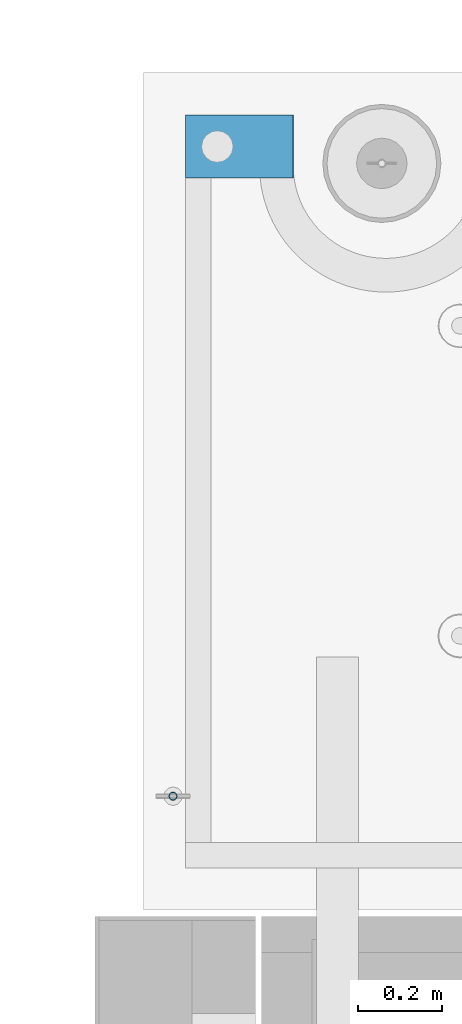
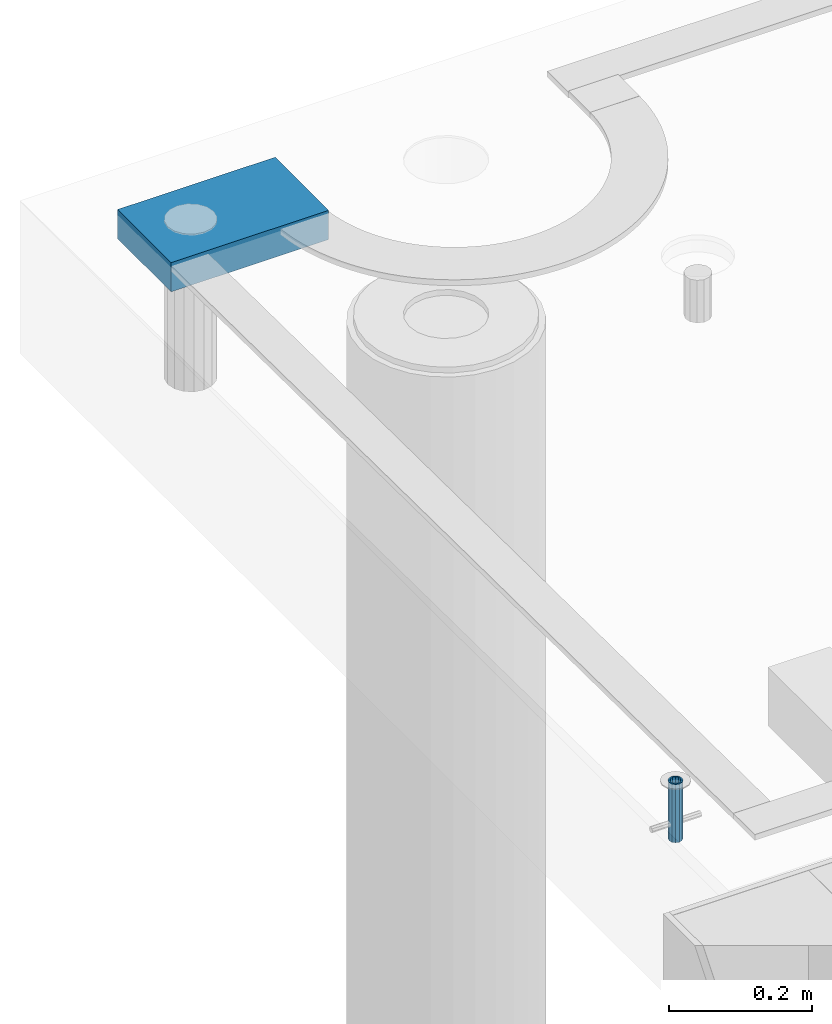
# One storey, part 154 of 350: 2 beams, 2 elements without a shape of their own.
"""IFC2X3 building model written with IfcOpenShell, lengths in millimetres."""

from ifc_helpers import new_model, si_unit, frame, origin_with_axes, place, context, subcontext, project, spatial, faceted_brep, material, type_object, element, aggregate, save


model = new_model("IFC2X3")

# Units and contexts
model_context = context("Model", 3, precision=1e-05, world=origin_with_axes())
body_context = subcontext(model_context, "Body", "Model", "MODEL_VIEW")
ifc_project = project(units=[si_unit("LENGTHUNIT", "METRE", prefix="MILLI"), si_unit("AREAUNIT", "SQUARE_METRE"), si_unit("VOLUMEUNIT", "CUBIC_METRE"), si_unit("MASSUNIT", "GRAM", prefix="KILO"), si_unit("TIMEUNIT", "SECOND"), si_unit("PLANEANGLEUNIT", "RADIAN"), si_unit("SOLIDANGLEUNIT", "STERADIAN"), si_unit("THERMODYNAMICTEMPERATUREUNIT", "DEGREE_CELSIUS"), si_unit("LUMINOUSINTENSITYUNIT", "LUMEN")], contexts=[model_context])

# Site, building, storey
site_placement = place(None, origin_with_axes())
site = spatial("IfcSite", under=ifc_project, at=site_placement, CompositionType="ELEMENT")
building_placement = place(site_placement, origin_with_axes())
building = spatial("IfcBuilding", under=site, at=building_placement, CompositionType="ELEMENT")
storey_placement = place(building_placement, origin_with_axes())
storey = spatial("IfcBuildingStorey", under=building, at=storey_placement, Name="2", CompositionType="ELEMENT", Elevation=0.0)

# Assemblies, beams
assembly_1_placement = place(storey_placement, origin_with_axes())
assembly_1 = element("IfcElementAssembly", 1, at=assembly_1_placement, inside=storey, AssemblyPlace="NOTDEFINED", PredefinedType="REINFORCEMENT_UNIT")
ifc_material_1 = material(Name="CONCRETE/Concrete_Undefined")
beam_type_1 = type_object("IfcBeamType", PredefinedType="NOTDEFINED")
beam_1_placement = place(assembly_1_placement, frame((7834.97852488622, 22709.9981419457, 87691.8130006467), z_axis=(-0.000811736999627788, 6.99999872856177e-09, 0.999999670541467), x_axis=(0.99999967050638, -8.37699998998561e-06, 0.000811736999618736)))
beam_1 = element("IfcBeam", 2, at=beam_1_placement, type_object=beam_type_1, material=ifc_material_1, context=body_context, shape_type="Brep", body=[
    faceted_brep([(0.0, 75.0, -25.0), (1.81898940354586e-12, 75.0, 25.0), (254.995831308013, 74.9999999999964, 24.9999999999709), (254.995831308012, 74.9999999999964, -25.0000000000146), (1.81898940354586e-12, -75.0000000000009, 25.0), (254.995831308014, -75.0000000000036, 24.9999999999854), (0.0, -75.0, -25.0), (254.995831308011, -75.0000000000036, -25.0000000000146)], [[[0, 1, 2, 3]], [[1, 4, 5, 2]], [[4, 6, 7, 5]], [[6, 0, 3, 7]], [[5, 7, 3, 2]], [[6, 4, 1, 0]]]),
])
assembly_2_placement = place(assembly_1_placement, origin_with_axes())
assembly_2 = element("IfcElementAssembly", 3, at=assembly_2_placement, Name="Steel Assembly", AssemblyPlace="NOTDEFINED", PredefinedType="RIGID_FRAME")
aggregate(assembly_1, [assembly_2, beam_1])
ifc_material_2 = material(Name="STEEL/1.4301")
beam_type_2 = type_object("IfcBeamType", PredefinedType="NOTDEFINED")
beam_2_placement = place(assembly_2_placement, frame((7804.99906039055, 21170.0168887753, 87730.9999983246), z_axis=(-1.43919999976435e-05, -0.999999999896435, 0.0), x_axis=(0.0, 0.0, -1.0)))
beam_2 = element("IfcBeam", 4, at=beam_2_placement, type_object=beam_type_2, material=ifc_material_2, context=body_context, shape_type="Brep", body=[
    faceted_brep([(0.0, -8.0, 0.0), (0.0, -6.92820323027263, 4.0), (100.000000000029, -6.92820323027263, 4.0), (100.000000000029, -7.99999999999636, 0.0), (0.0, -4.0, 6.92820323027627), (100.000000000029, -4.0, 6.92820323027536), (0.0, 0.0, 8.0), (100.000000000029, 3.63797880709171e-12, 8.0), (0.0, 4.0, 6.92820323027627), (100.000000000029, 4.0, 6.92820323027536), (0.0, 6.92820323027263, 4.0), (100.000000000029, 6.92820323027627, 3.99999999999909), (0.0, 8.0, 0.0), (100.000000000029, 8.0, 0.0), (0.0, 6.92820323027263, -4.0), (100.000000000029, 6.92820323027627, -4.00000000000091), (0.0, 4.0, -6.92820323027627), (100.000000000029, 4.00000000000364, -6.92820323027536), (0.0, 0.0, -8.0), (100.000000000029, 3.63797880709171e-12, -8.00000000000091), (0.0, -4.0, -6.92820323027627), (100.000000000029, -3.99999999999636, -6.92820323027627), (0.0, -6.92820323027263, -4.0), (100.000000000029, -6.92820323027263, -4.0), (0.0, -10.4999999999927, -1.45519152283669e-11), (0.0, -9.09326673972828, -5.25000000001455), (100.000000000262, -9.09326673972828, -5.25000000001455), (100.000000000262, -10.4999999999927, -1.45519152283669e-11), (0.0, -5.24999999998545, -9.09326673974283), (100.000000000262, -5.24999999998545, -9.09326673974283), (0.0, 7.27595761418343e-12, -10.5), (100.000000000262, 7.27595761418343e-12, -10.5), (0.0, 5.25000000001455, -9.09326673975738), (100.000000000262, 5.25000000001455, -9.09326673975738), (0.0, 9.09326673975011, -5.25000000001455), (100.000000000262, 9.09326673975011, -5.25000000001455), (0.0, 10.5000000000073, -1.45519152283669e-11), (100.000000000262, 10.5000000000073, -1.45519152283669e-11), (0.0, 9.09326673975011, 5.25), (100.000000000262, 9.09326673975011, 5.25), (0.0, 5.25000000000728, 9.09326673972828), (100.000000000262, 5.25000000000728, 9.09326673972828), (0.0, 1.45519152283669e-11, 10.4999999999854), (100.000000000262, 1.45519152283669e-11, 10.4999999999854), (0.0, -5.24999999999272, 9.09326673972828), (100.000000000262, -5.24999999999272, 9.09326673972828), (0.0, -9.09326673972828, 5.24999999998545), (100.000000000262, -9.09326673972828, 5.24999999998545)], [[[0, 1, 2, 3]], [[1, 4, 5, 2]], [[4, 6, 7, 5]], [[6, 8, 9, 7]], [[8, 10, 11, 9]], [[10, 12, 13, 11]], [[12, 14, 15, 13]], [[14, 16, 17, 15]], [[16, 18, 19, 17]], [[18, 20, 21, 19]], [[20, 22, 23, 21]], [[22, 0, 3, 23]], [[24, 25, 26, 27]], [[25, 28, 29, 26]], [[28, 30, 31, 29]], [[30, 32, 33, 31]], [[32, 34, 35, 33]], [[34, 36, 37, 35]], [[36, 38, 39, 37]], [[38, 40, 41, 39]], [[40, 42, 43, 41]], [[42, 44, 45, 43]], [[44, 46, 47, 45]], [[46, 24, 27, 47]], [[29, 31, 33, 35, 37, 39, 41, 43, 45, 47, 27, 26], [5, 7, 9, 11, 13, 15, 17, 19, 21, 23, 3, 2]], [[46, 44, 42, 40, 38, 36, 34, 32, 30, 28, 25, 24], [22, 20, 18, 16, 14, 12, 10, 8, 6, 4, 1, 0]]]),
])
aggregate(assembly_2, [beam_2])

save(model, "model.ifc")
